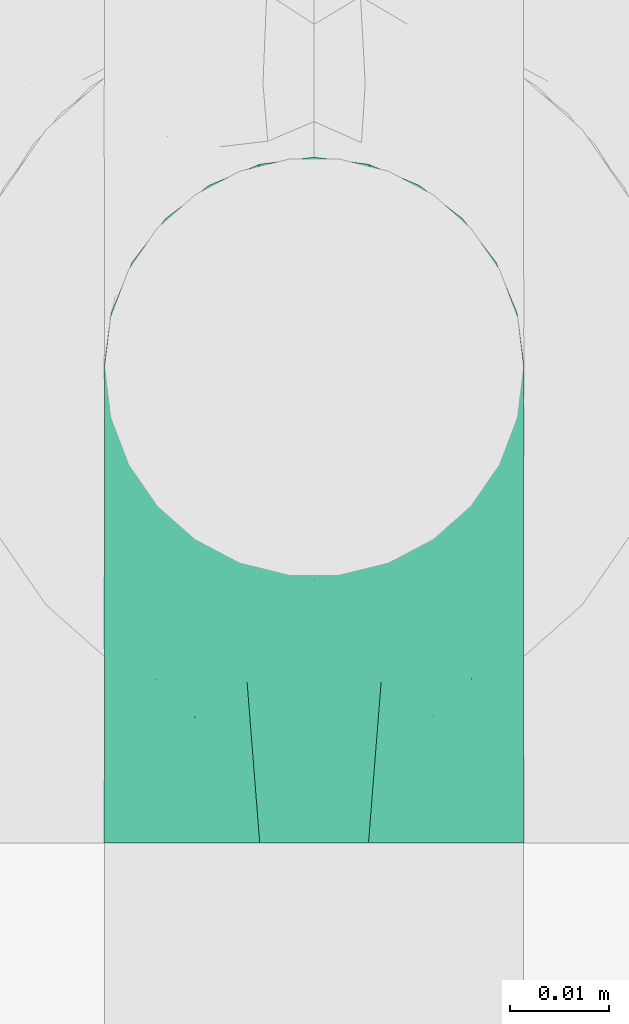
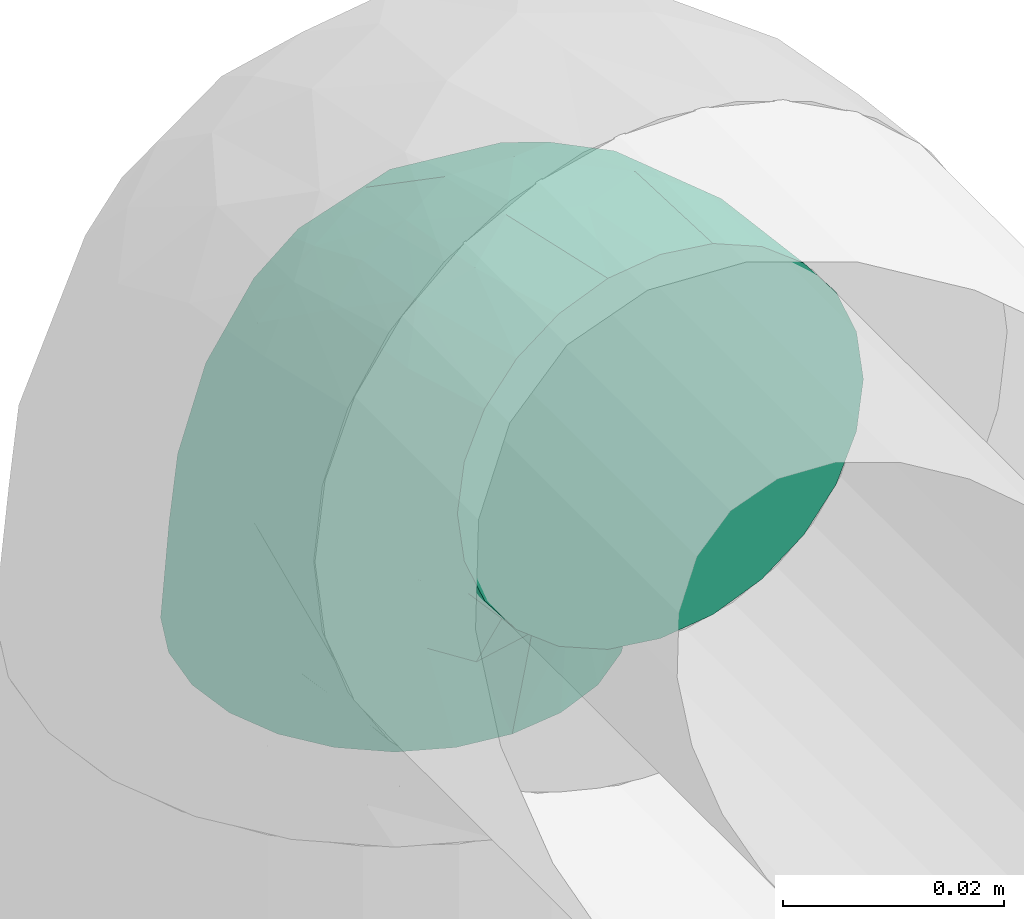
# One storey, part 32 of 39: 1 flow fitting.
"""IFC2X3 building model written with IfcOpenShell, lengths in millimetres."""

from ifc_helpers import new_model, entity, si_unit, converted_unit, derived_unit, direction, frame, origin, place, context, subcontext, project, spatial, faceted_brep, source, transform, mapped, material, type_object, type_shapes, element, save


model = new_model("IFC2X3")

# Units and contexts
model_context = context("Model", 3, precision=0.01, world=origin(), true_north=direction((6.12303176911189e-17, 1.0)))
body_context = subcontext(model_context, "Body", "Model", "MODEL_VIEW")
ifc_project = project(units=[si_unit("LENGTHUNIT", "METRE", prefix="MILLI"), si_unit("AREAUNIT", "SQUARE_METRE"), si_unit("VOLUMEUNIT", "CUBIC_METRE"), converted_unit("PLANEANGLEUNIT", "DEGREE", entity("IfcRatioMeasure", 0.0174532925199433), si_unit("PLANEANGLEUNIT", "RADIAN"), dimensions=[0, 0, 0, 0, 0, 0, 0]), si_unit("MASSUNIT", "GRAM", prefix="KILO"), derived_unit("MASSDENSITYUNIT", [(si_unit("MASSUNIT", "GRAM", prefix="KILO"), 1), (si_unit("LENGTHUNIT", "METRE"), -3)]), derived_unit("MOMENTOFINERTIAUNIT", [(si_unit("LENGTHUNIT", "METRE"), 4)]), si_unit("TIMEUNIT", "SECOND"), si_unit("FREQUENCYUNIT", "HERTZ"), si_unit("THERMODYNAMICTEMPERATUREUNIT", "DEGREE_CELSIUS"), derived_unit("THERMALTRANSMITTANCEUNIT", [(si_unit("MASSUNIT", "GRAM", prefix="KILO"), 1), (si_unit("THERMODYNAMICTEMPERATUREUNIT", "KELVIN"), -1), (si_unit("TIMEUNIT", "SECOND"), -3)]), derived_unit("VOLUMETRICFLOWRATEUNIT", [(si_unit("LENGTHUNIT", "METRE"), 3), (si_unit("TIMEUNIT", "SECOND"), -1)]), derived_unit("MASSFLOWRATEUNIT", [(si_unit("MASSUNIT", "GRAM", prefix="KILO"), 1), (si_unit("TIMEUNIT", "SECOND"), -1)]), derived_unit("ROTATIONALFREQUENCYUNIT", [(si_unit("TIMEUNIT", "SECOND"), -1)]), si_unit("ELECTRICCURRENTUNIT", "AMPERE"), si_unit("ELECTRICVOLTAGEUNIT", "VOLT"), si_unit("POWERUNIT", "WATT"), si_unit("FORCEUNIT", "NEWTON", prefix="KILO"), si_unit("ILLUMINANCEUNIT", "LUX"), si_unit("LUMINOUSFLUXUNIT", "LUMEN"), si_unit("LUMINOUSINTENSITYUNIT", "CANDELA"), derived_unit("USERDEFINED", [(si_unit("MASSUNIT", "GRAM", prefix="KILO"), -1), (si_unit("LENGTHUNIT", "METRE"), -2), (si_unit("TIMEUNIT", "SECOND"), 3), (si_unit("LUMINOUSFLUXUNIT", "LUMEN"), 1)]), derived_unit("LINEARVELOCITYUNIT", [(si_unit("LENGTHUNIT", "METRE"), 1), (si_unit("TIMEUNIT", "SECOND"), -1)]), si_unit("PRESSUREUNIT", "PASCAL"), derived_unit("USERDEFINED", [(si_unit("LENGTHUNIT", "METRE"), -2), (si_unit("MASSUNIT", "GRAM", prefix="KILO"), 1), (si_unit("TIMEUNIT", "SECOND"), -2)]), derived_unit("LINEARFORCEUNIT", [(si_unit("MASSUNIT", "GRAM", prefix="KILO"), 1), (si_unit("LENGTHUNIT", "METRE"), 1), (si_unit("TIMEUNIT", "SECOND"), -2), (si_unit("LENGTHUNIT", "METRE"), -1)]), derived_unit("PLANARFORCEUNIT", [(si_unit("MASSUNIT", "GRAM", prefix="KILO"), 1), (si_unit("LENGTHUNIT", "METRE"), 1), (si_unit("TIMEUNIT", "SECOND"), -2), (si_unit("LENGTHUNIT", "METRE"), -2)])], contexts=[model_context])

# Site, building, storey
site_placement = place(None, origin())
site = spatial("IfcSite", under=ifc_project, at=site_placement, CompositionType="ELEMENT")
building_placement = place(site_placement, origin())
building = spatial("IfcBuilding", under=site, at=building_placement, CompositionType="ELEMENT")
storey_placement = place(building_placement, frame((0.0, 0.0, 24000.0)))
storey = spatial("IfcBuildingStorey", under=building, at=storey_placement, Name="07", CompositionType="ELEMENT", Elevation=24000.0)

# Flow fitting
ifc_material = material()
pipe_fitting_type = type_object("IfcPipeFittingType", Name="ADSK_1", PredefinedType="NOTDEFINED", material=ifc_material)
shared_shape = source(origin(), body_context, "Body", "Brep", [
    faceted_brep([(-48.0, 10.6, -18.36), (-48.0, 5.49, -20.48), (-48.0, 0.0, -21.2), (-48.0, -5.49, -20.48), (-48.0, -10.6, -18.36), (-48.0, -14.99, -14.99), (-48.0, -18.36, -10.6), (-48.0, -20.48, -5.49), (-48.0, -21.2, 0.0), (-48.0, -20.48, 5.49), (-48.0, -18.36, 10.6), (-48.0, -14.99, 14.99), (-48.0, -10.6, 18.36), (-48.0, -5.49, 20.48), (-48.0, 0.0, 21.2), (-48.0, 5.49, 20.48), (-48.0, 10.6, 18.36), (-48.0, 14.99, 14.99), (-48.0, 18.36, 10.6), (-48.0, 20.48, 5.49), (-48.0, 21.2, 0.0), (-48.0, 20.48, -5.49), (-48.0, 18.36, -10.6), (-48.0, 14.99, -14.99), (-5.49, 48.0, -20.48), (-10.6, 48.0, -18.36), (-14.99, 48.0, -14.99), (-18.36, 48.0, -10.6), (-20.48, 48.0, -5.49), (-21.2, 48.0, 0.0), (-20.48, 48.0, 5.49), (-18.36, 48.0, 10.6), (-14.99, 48.0, 14.99), (-10.6, 48.0, 18.36), (-5.49, 48.0, 20.48), (0.0, 48.0, 21.2), (5.49, 48.0, 20.48), (10.6, 48.0, 18.36), (14.99, 48.0, 14.99), (18.36, 48.0, 10.6), (20.48, 48.0, 5.49), (21.2, 48.0, 0.0), (20.48, 48.0, -5.49), (18.36, 48.0, -10.6), (14.99, 48.0, -14.99), (10.6, 48.0, -18.36), (5.49, 48.0, -20.48), (0.0, 48.0, -21.2), (-35.25, -16.22, 12.01), (-34.76, -18.57, 0.0), (-20.87, -12.37, 10.9), (-31.49, -11.78, 15.9), (-37.0, -2.58, 20.86), (-33.89, 3.62, 21.15), (-31.81, -18.14, 6.76), (-5.78, 5.78, 17.67), (-19.42, -4.1, 17.86), (-9.6, -3.39, 13.73), (-35.44, -7.73, 19.13), (11.78, 31.49, 15.9), (-5.93, -5.46, 6.95), (-18.45, -13.78, 5.46), (-10.29, -8.43, 0.0), (-24.6, 0.55, 20.62), (-37.28, 17.94, 13.81), (-33.38, 22.85, 9.59), (-41.46, 20.06, 8.75), (-29.51, 20.45, 15.16), (-15.04, 10.79, 21.13), (-7.08, 16.98, 20.93), (-8.39, 23.51, 21.15), (-40.86, 13.03, 17.26), (-8.05, 41.26, 19.83), (-3.21, 35.97, 21.14), (8.53, 19.66, 14.74), (4.1, 19.42, 17.86), (-37.72, 22.66, 4.78), (-37.07, 8.58, 19.98), (-13.0, 5.43, 19.97), (-3.78, 13.93, 19.7), (3.02, 8.69, 13.43), (-2.27, -0.05, 10.65), (6.22, 6.99, 7.09), (-22.25, 34.6, 9.45), (18.14, 31.81, 6.76), (16.22, 35.25, 12.01), (12.37, 20.87, 10.9), (7.73, 35.44, 19.13), (-21.52, -15.93, 0.0), (2.58, 37.0, 20.86), (18.57, 34.76, 0.0), (13.78, 18.45, 5.46), (15.93, 21.52, 0.0), (-20.03, -8.54, 14.9), (-28.6, 28.6, 5.16), (-24.79, 34.6, 0.0), (-34.6, 24.79, 0.0), (-22.81, 37.41, 4.68), (-23.36, 26.33, 14.79), (-13.68, 37.05, 17.49), (-17.72, 38.12, 13.73), (-26.25, 27.3, 11.24), (-9.71, 32.34, 20.14), (-17.26, 25.6, 18.71), (-26.33, 9.99, 20.77), (-24.06, 6.05, 21.2), (-25.02, 15.46, 19.56), (-24.3, 20.72, 17.57), (-31.95, 15.23, 17.8), (-13.53, 24.7, 20.21), (-17.6, 17.6, 20.6), (-0.55, 24.6, 20.62), (-11.41, -7.48, 10.43), (0.93, -0.93, 0.0), (8.43, 10.29, 0.0), (-11.41, -7.48, -10.43), (-20.1, -8.84, -14.66), (-9.6, -3.39, -13.73), (7.73, 35.44, -19.13), (4.1, 19.42, -17.86), (-0.55, 24.6, -20.62), (-38.12, 17.72, -13.73), (-37.05, 13.68, -17.49), (-32.34, 9.71, -20.14), (-41.26, 8.05, -19.83), (-37.41, 22.81, -4.68), (-23.51, 8.39, -21.15), (-35.97, 3.21, -21.14), (-28.6, 28.6, -5.16), (-31.81, -18.14, -6.76), (-18.45, -13.78, -5.46), (-25.6, 17.26, -18.71), (-19.42, -4.1, -17.86), (-17.94, 37.28, -13.81), (-22.85, 33.38, -9.59), (-20.06, 41.46, -8.75), (-31.49, -11.78, -15.9), (-35.25, -16.22, -12.01), (8.53, 19.66, -14.74), (11.78, 31.49, -15.9), (-9.99, 26.33, -20.77), (-6.05, 24.06, -21.2), (-10.79, 15.04, -21.13), (-37.0, -2.58, -20.86), (-16.98, 7.08, -20.93), (-5.43, 13.0, -19.97), (-13.93, 3.78, -19.7), (-20.87, -12.37, -10.9), (-26.33, 23.36, -14.79), (-22.66, 37.72, -4.78), (13.78, 18.45, -5.46), (18.14, 31.81, -6.76), (-15.46, 25.02, -19.56), (-20.72, 24.3, -17.57), (16.22, 35.25, -12.01), (-13.03, 40.86, -17.26), (-8.58, 37.07, -19.98), (2.58, 37.0, -20.86), (-3.62, 33.89, -21.15), (-34.6, 22.25, -9.45), (6.22, 6.99, -7.09), (-20.45, 29.51, -15.16), (-35.44, -7.73, -19.13), (12.37, 20.87, -10.9), (-27.3, 26.25, -11.24), (-15.23, 31.95, -17.8), (-24.7, 13.53, -20.21), (-17.6, 17.6, -20.6), (-24.6, 0.55, -20.62), (-5.78, 5.78, -17.67), (3.02, 8.69, -13.43), (-5.93, -5.46, -6.95), (-2.27, -0.05, -10.65)], [[[0, 1, 2, 3, 4, 5, 6, 7, 8, 9, 10, 11, 12, 13, 14, 15, 16, 17, 18, 19, 20, 21, 22, 23]], [[24, 25, 26, 27, 28, 29, 30, 31, 32, 33, 34, 35, 36, 37, 38, 39, 40, 41, 42, 43, 44, 45, 46, 47]], [[10, 48, 11]], [[9, 8, 49]], [[48, 50, 51]], [[14, 52, 53]], [[10, 54, 48]], [[9, 54, 10]], [[55, 56, 57]], [[51, 12, 11]], [[51, 58, 12]], [[59, 38, 37]], [[60, 61, 62]], [[58, 56, 63]], [[64, 65, 66]], [[67, 65, 64]], [[68, 69, 70]], [[16, 71, 17]], [[13, 52, 14]], [[34, 72, 73]], [[14, 53, 15]], [[17, 64, 18]], [[74, 59, 75]], [[20, 19, 76]], [[66, 19, 18]], [[77, 15, 53]], [[15, 77, 16]], [[69, 78, 79]], [[80, 81, 82]], [[31, 30, 83]], [[84, 85, 86]], [[59, 87, 75]], [[61, 54, 88]], [[35, 89, 36]], [[84, 40, 39]], [[35, 34, 73]], [[90, 40, 84]], [[39, 38, 85]], [[12, 58, 13]], [[85, 84, 39]], [[91, 84, 86]], [[84, 92, 90]], [[87, 37, 36]], [[93, 56, 51]], [[65, 94, 76]], [[94, 95, 96]], [[84, 91, 92]], [[95, 97, 29]], [[98, 99, 100]], [[76, 94, 96]], [[101, 98, 83]], [[100, 99, 32]], [[102, 70, 73]], [[103, 102, 99]], [[94, 97, 95]], [[72, 99, 102]], [[72, 34, 33]], [[33, 32, 99]], [[9, 49, 54]], [[87, 59, 37]], [[104, 105, 68]], [[106, 103, 107]], [[106, 77, 104]], [[71, 64, 17]], [[108, 107, 67]], [[32, 31, 100]], [[109, 103, 110]], [[102, 109, 70]], [[89, 73, 111]], [[50, 48, 54]], [[51, 11, 48]], [[56, 58, 51]], [[88, 54, 49]], [[52, 58, 63]], [[50, 112, 93]], [[56, 55, 78]], [[38, 59, 85]], [[86, 85, 59]], [[89, 87, 36]], [[41, 40, 90]], [[111, 79, 75]], [[111, 75, 87]], [[75, 55, 80]], [[104, 77, 53]], [[71, 77, 108]], [[31, 83, 100]], [[98, 100, 83]], [[99, 98, 103]], [[106, 107, 108]], [[68, 70, 110]], [[111, 73, 70]], [[68, 110, 104]], [[68, 63, 78]], [[57, 93, 112]], [[80, 55, 57]], [[61, 50, 54]], [[80, 82, 86]], [[81, 57, 112]], [[74, 86, 59]], [[60, 113, 82]], [[82, 114, 91]], [[101, 94, 65]], [[97, 94, 83]], [[73, 89, 35]], [[87, 89, 111]], [[58, 52, 13]], [[53, 52, 63]], [[104, 53, 105]], [[106, 104, 110]], [[20, 76, 96]], [[76, 19, 66]], [[103, 106, 110]], [[77, 106, 108]], [[103, 98, 107]], [[67, 107, 98]], [[67, 98, 101]], [[108, 67, 64]], [[53, 63, 105]], [[63, 68, 105]], [[83, 30, 97]], [[29, 97, 30]], [[62, 113, 60]], [[112, 61, 60]], [[61, 88, 62]], [[86, 82, 91]], [[56, 78, 63]], [[114, 82, 113]], [[114, 92, 91]], [[79, 78, 55]], [[75, 79, 55]], [[69, 79, 111]], [[70, 69, 111]], [[78, 69, 68]], [[77, 71, 16]], [[64, 71, 108]], [[64, 66, 18]], [[76, 66, 65]], [[99, 72, 33]], [[73, 72, 102]], [[94, 101, 83]], [[67, 101, 65]], [[75, 80, 74]], [[80, 86, 74]], [[70, 109, 110]], [[102, 103, 109]], [[50, 93, 51]], [[57, 56, 93]], [[61, 112, 50]], [[81, 112, 60]], [[82, 81, 60]], [[80, 57, 81]], [[115, 116, 117]], [[118, 119, 120]], [[121, 122, 23]], [[123, 124, 122]], [[96, 125, 20]], [[123, 126, 127]], [[128, 96, 95]], [[129, 130, 88]], [[123, 122, 131]], [[116, 132, 117]], [[133, 134, 135]], [[0, 124, 1]], [[5, 136, 137]], [[138, 119, 139]], [[129, 88, 49]], [[140, 141, 142]], [[6, 5, 137]], [[45, 118, 46]], [[143, 3, 2]], [[144, 145, 146]], [[6, 129, 7]], [[129, 137, 147]], [[127, 2, 1]], [[148, 122, 121]], [[128, 125, 96]], [[134, 128, 149]], [[95, 149, 128]], [[150, 151, 92]], [[29, 28, 149]], [[152, 131, 153]], [[26, 133, 27]], [[154, 44, 43]], [[136, 5, 4]], [[26, 25, 155]], [[156, 25, 24]], [[47, 157, 158]], [[47, 46, 157]], [[22, 21, 159]], [[160, 150, 114]], [[134, 133, 161]], [[142, 144, 126]], [[45, 139, 118]], [[162, 136, 4]], [[156, 24, 158]], [[1, 124, 127]], [[115, 147, 116]], [[44, 154, 139]], [[139, 45, 44]], [[154, 163, 139]], [[162, 4, 3]], [[41, 90, 42]], [[130, 129, 147]], [[49, 7, 129]], [[42, 151, 43]], [[0, 23, 122]], [[47, 158, 24]], [[136, 162, 132]], [[135, 28, 27]], [[42, 90, 151]], [[164, 148, 159]], [[152, 156, 140]], [[155, 133, 26]], [[165, 153, 161]], [[23, 22, 121]], [[166, 131, 167]], [[123, 166, 126]], [[143, 127, 168]], [[147, 137, 136]], [[8, 7, 49]], [[129, 6, 137]], [[143, 162, 3]], [[168, 146, 132]], [[168, 132, 162]], [[132, 169, 117]], [[43, 151, 154]], [[92, 151, 90]], [[163, 154, 151]], [[119, 118, 139]], [[157, 118, 120]], [[138, 139, 163]], [[119, 169, 145]], [[140, 156, 158]], [[155, 156, 165]], [[22, 159, 121]], [[148, 121, 159]], [[122, 148, 131]], [[152, 153, 165]], [[142, 126, 167]], [[168, 127, 126]], [[142, 167, 140]], [[142, 120, 145]], [[169, 170, 117]], [[160, 171, 172]], [[115, 172, 171]], [[171, 62, 130]], [[119, 170, 169]], [[170, 163, 160]], [[150, 163, 151]], [[113, 171, 160]], [[164, 128, 134]], [[125, 128, 159]], [[127, 143, 2]], [[162, 143, 168]], [[118, 157, 46]], [[158, 157, 120]], [[140, 158, 141]], [[152, 140, 167]], [[29, 149, 95]], [[149, 28, 135]], [[131, 152, 167]], [[156, 152, 165]], [[131, 148, 153]], [[161, 153, 148]], [[161, 148, 164]], [[165, 161, 133]], [[158, 120, 141]], [[120, 142, 141]], [[159, 21, 125]], [[20, 125, 21]], [[115, 130, 147]], [[114, 113, 160]], [[62, 171, 113]], [[62, 88, 130]], [[160, 163, 150]], [[150, 92, 114]], [[119, 145, 120]], [[146, 145, 169]], [[132, 146, 169]], [[144, 146, 168]], [[126, 144, 168]], [[145, 144, 142]], [[156, 155, 25]], [[133, 155, 165]], [[133, 135, 27]], [[149, 135, 134]], [[122, 124, 0]], [[127, 124, 123]], [[128, 164, 159]], [[161, 164, 134]], [[163, 170, 138]], [[170, 119, 138]], [[126, 166, 167]], [[123, 131, 166]], [[147, 136, 116]], [[132, 116, 136]], [[172, 115, 117]], [[130, 115, 171]], [[117, 170, 172]], [[160, 172, 170]]]),
])
type_shapes(pipe_fitting_type, [shared_shape])
flow_fitting_placement = place(storey_placement, frame((31080.0, 2121.96, 2825.41), z_axis=(1.0, 0.0, 0.0), x_axis=(0.0, 0.0, 1.0)))
element("IfcFlowFitting", 1, at=flow_fitting_placement, inside=storey, type_object=pipe_fitting_type, material=ifc_material, Name="ADSK_1", ObjectType="ADSK_1", context=body_context, shape_type="MappedRepresentation", body=[
    mapped(shared_shape, transform((0.0, 0.0, 0.0), scale=1.0)),
])

save(model, "model.ifc")
